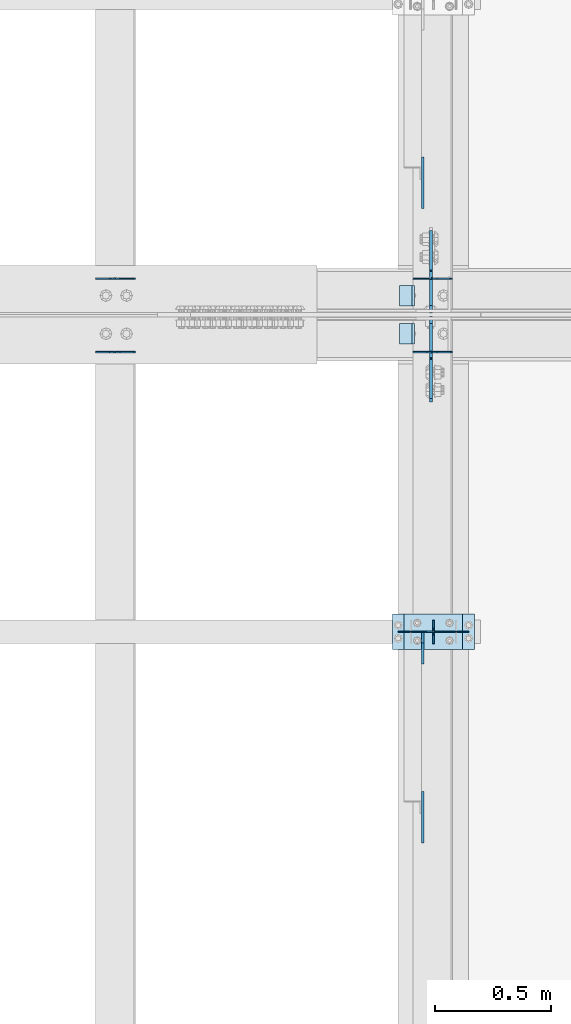
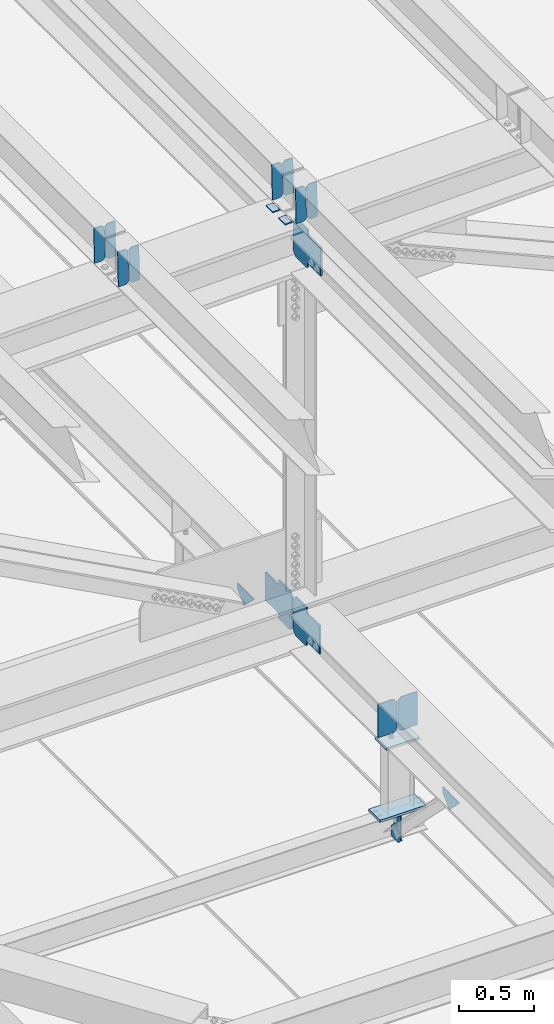
# One storey, part 3284 of 3843: 22 plates, 10 elements without a shape of their own.
"""IFC2X3 building model written with IfcOpenShell, lengths in millimetres."""

from ifc_helpers import new_model, si_unit, frame, origin_with_axes, place, context, subcontext, project, spatial, faceted_brep, material, type_object, element, aggregate, save


model = new_model("IFC2X3")

# Units and contexts
model_context = context("Model", 3, precision=1e-05, world=origin_with_axes())
body_context = subcontext(model_context, "Body", "Model", "MODEL_VIEW")
ifc_project = project(units=[si_unit("LENGTHUNIT", "METRE", prefix="MILLI"), si_unit("AREAUNIT", "SQUARE_METRE"), si_unit("VOLUMEUNIT", "CUBIC_METRE"), si_unit("MASSUNIT", "GRAM", prefix="KILO"), si_unit("TIMEUNIT", "SECOND"), si_unit("PLANEANGLEUNIT", "RADIAN"), si_unit("SOLIDANGLEUNIT", "STERADIAN"), si_unit("THERMODYNAMICTEMPERATUREUNIT", "DEGREE_CELSIUS"), si_unit("LUMINOUSINTENSITYUNIT", "LUMEN")], contexts=[model_context])

# Site, building, storey
site_placement = place(None, origin_with_axes())
site = spatial("IfcSite", under=ifc_project, at=site_placement, CompositionType="ELEMENT")
building_placement = place(site_placement, origin_with_axes())
building = spatial("IfcBuilding", under=site, at=building_placement, Name="Undefined", CompositionType="ELEMENT")
storey_placement = place(building_placement, origin_with_axes())
storey = spatial("IfcBuildingStorey", under=building, at=storey_placement, Name="Undefined", CompositionType="ELEMENT", Elevation=0.0)

# Assembly, plates
assembly_1_placement = place(storey_placement, origin_with_axes())
assembly_1 = element("IfcElementAssembly", 1, at=assembly_1_placement, inside=storey, Name="BEAM", AssemblyPlace="NOTDEFINED", PredefinedType="RIGID_FRAME")
ifc_material = material(Name="STEEL/A572-50")
plate_type_1 = type_object("IfcPlateType", PredefinedType="NOTDEFINED")
plate_1_placement = place(assembly_1_placement, frame((42144.6964817676, 59070.8529243863, 45578.562311739), z_axis=(-0.0211520980636923, 7.39979999707428e-05, 0.999776266607585), x_axis=(-0.999776269345987, -1.58399999781977e-06, -0.021152098007311)))
plate_1 = element("IfcPlate", 2, at=plate_1_placement, type_object=plate_type_1, material=ifc_material, Name="PLATE", context=body_context, shape_type="Brep", body=[
    faceted_brep([(0.0, -3.17499999999927, 0.0), (6.83940015733242e-10, -3.17499999996653, 288.924999998613), (6.54836185276508e-10, 3.17500000001746, 288.924999998591), (0.0, 3.17499999999927, 0.0), (60.3250007643655, -3.17500000017753, 288.924999998606), (60.3250007643219, 3.17499999979918, 288.924999998584), (79.3750000013097, -3.17500000025029, 269.875000761494), (79.375000001266, 3.17499999972642, 269.875000761487), (79.375000000713, -3.17500000026484, 19.0499992370605), (79.3750000006985, 3.17499999971187, 19.0499992370533), (60.325000763667, -3.17500000020664, -1.45519152283669e-11), (60.3250007636234, 3.17499999977736, -3.63797880709171e-11)], [[[0, 1, 2, 3]], [[1, 4, 5, 2]], [[4, 6, 7, 5]], [[6, 8, 9, 7]], [[8, 10, 11, 9]], [[10, 0, 3, 11]], [[5, 7, 9, 11, 3, 2]], [[10, 8, 6, 4, 1, 0]]]),
])
plate_2_placement = place(assembly_1_placement, frame((42058.990661078, 59070.8527920629, 45576.7490481436), z_axis=(-0.0211520980636923, 7.39979999707428e-05, 0.999776266607585), x_axis=(-0.999776269345987, -1.58399999781977e-06, -0.021152098007311)))
plate_2 = element("IfcPlate", 3, at=plate_2_placement, type_object=plate_type_1, material=ifc_material, Name="PLATE", context=body_context, shape_type="Brep", body=[
    faceted_brep([(4.36557456851006e-11, -3.17499999998836, 19.0499992370969), (6.11180439591408e-10, -3.17499999996653, 269.875000761516), (5.96628524363041e-10, 3.17500000001746, 269.875000761502), (1.45519152283669e-11, 3.17499999998836, 19.0499992370824), (19.0499992376572, -3.17500000003201, 288.924999998606), (19.0499992376281, 3.1749999999447, 288.924999998584), (79.3750000013242, -3.17500000025029, 288.924999998591), (79.3750000013097, 3.1749999997337, 288.92499999857), (79.3750000006548, -3.17500000026484, -2.18278728425503e-11), (79.3750000006403, 3.17499999969732, -2.91038304567337e-11), (19.0499992370023, -3.17500000005384, 0.0), (19.0499992369587, 3.17499999992287, -1.45519152283669e-11)], [[[0, 1, 2, 3]], [[1, 4, 5, 2]], [[4, 6, 7, 5]], [[6, 8, 9, 7]], [[8, 10, 11, 9]], [[10, 0, 3, 11]], [[5, 7, 9, 11, 3, 2]], [[10, 8, 6, 4, 1, 0]]]),
])

assembly_2_placement = place(storey_placement, origin_with_axes())
assembly_2 = element("IfcElementAssembly", 4, at=assembly_2_placement, inside=storey, Name="BEAM", AssemblyPlace="NOTDEFINED", PredefinedType="RIGID_FRAME")
plate_3_placement = place(assembly_2_placement, frame((42144.696478349, 58753.3983628377, 45578.5611420288), z_axis=(-0.0211520980722271, -7.83190000220203e-05, 0.999776266278249), x_axis=(-0.999776269345987, 1.58400000145775e-06, -0.021152098007311)))
plate_3 = element("IfcPlate", 5, at=plate_3_placement, type_object=plate_type_1, material=ifc_material, Name="PLATE", context=body_context, shape_type="Brep", body=[
    faceted_brep([(0.0, -3.17499999999927, 0.0), (6.83940015733242e-10, -3.17499999996653, 288.924999998613), (6.54836185276508e-10, 3.17500000001746, 288.924999998591), (0.0, 3.17499999999927, 0.0), (60.3250007643655, -3.17500000017753, 288.924999998606), (60.3250007643219, 3.17499999979918, 288.924999998584), (79.3750000013097, -3.17500000025029, 269.875000761494), (79.375000001266, 3.17499999972642, 269.875000761487), (79.375000000713, -3.17500000026484, 19.0499992370605), (79.3750000006985, 3.17499999971187, 19.0499992370533), (60.325000763667, -3.17500000020664, -1.45519152283669e-11), (60.3250007636234, 3.17499999977736, -3.63797880709171e-11)], [[[0, 1, 2, 3]], [[1, 4, 5, 2]], [[4, 6, 7, 5]], [[6, 8, 9, 7]], [[8, 10, 11, 9]], [[10, 0, 3, 11]], [[5, 7, 9, 11, 3, 2]], [[10, 8, 6, 4, 1, 0]]]),
])
plate_4_placement = place(assembly_2_placement, frame((42058.9906576593, 58753.3985048813, 45576.7478784327), z_axis=(-0.0211520980722271, -7.83190000220203e-05, 0.999776266278249), x_axis=(-0.999776269345987, 1.58400000145775e-06, -0.021152098007311)))
plate_4 = element("IfcPlate", 6, at=plate_4_placement, type_object=plate_type_1, material=ifc_material, Name="PLATE", context=body_context, shape_type="Brep", body=[
    faceted_brep([(4.36557456851006e-11, -3.17499999998836, 19.0499992370969), (6.11180439591408e-10, -3.17499999996653, 269.875000761516), (5.96628524363041e-10, 3.17500000001746, 269.875000761502), (1.45519152283669e-11, 3.17499999998836, 19.0499992370824), (19.0499992376572, -3.17500000003201, 288.924999998606), (19.0499992376281, 3.1749999999447, 288.924999998584), (79.3750000013242, -3.17500000025029, 288.924999998591), (79.3750000013097, 3.1749999997337, 288.92499999857), (79.3750000006548, -3.17500000026484, -2.18278728425503e-11), (79.3750000006403, 3.17499999969732, -2.91038304567337e-11), (19.0499992370023, -3.17500000005384, 0.0), (19.0499992369587, 3.17499999992287, -1.45519152283669e-11)], [[[0, 1, 2, 3]], [[1, 4, 5, 2]], [[4, 6, 7, 5]], [[6, 8, 9, 7]], [[8, 10, 11, 9]], [[10, 0, 3, 11]], [[5, 7, 9, 11, 3, 2]], [[10, 8, 6, 4, 1, 0]]]),
])

assembly_3_placement = place(storey_placement, origin_with_axes())
assembly_3 = element("IfcElementAssembly", 7, at=assembly_3_placement, inside=storey, Name="BEAM", AssemblyPlace="NOTDEFINED", PredefinedType="RIGID_FRAME")
plate_5_placement = place(assembly_3_placement, frame((40773.0964741001, 59070.8557457717, 45542.3034593218), z_axis=(-0.0211520980514033, 6.45460000159801e-05, 0.99977626726275), x_axis=(-0.999776269345987, -1.58399999781977e-06, -0.021152098007311)))
plate_5 = element("IfcPlate", 8, at=plate_5_placement, type_object=plate_type_1, material=ifc_material, Name="PLATE", context=body_context, shape_type="Brep", body=[
    faceted_brep([(0.0, -3.17499999999927, 0.0), (6.83940015733242e-10, -3.17499999996653, 288.924999998613), (6.54836185276508e-10, 3.17500000001746, 288.924999998591), (0.0, 3.17499999999927, 0.0), (60.3250007643655, -3.17500000017753, 288.924999998606), (60.3250007643219, 3.17499999979918, 288.924999998584), (79.3750000013097, -3.17500000025029, 269.875000761494), (79.375000001266, 3.17499999972642, 269.875000761487), (79.375000000713, -3.17500000026484, 19.0499992370605), (79.3750000006985, 3.17499999971187, 19.0499992370533), (60.325000763667, -3.17500000020664, -1.45519152283669e-11), (60.3250007636234, 3.17499999977736, -3.63797880709171e-11)], [[[0, 1, 2, 3]], [[1, 4, 5, 2]], [[4, 6, 7, 5]], [[6, 8, 9, 7]], [[8, 10, 11, 9]], [[10, 0, 3, 11]], [[5, 7, 9, 11, 3, 2]], [[10, 8, 6, 4, 1, 0]]]),
])
plate_6_placement = place(assembly_3_placement, frame((40687.3906534104, 59070.8556287915, 45540.4901957237), z_axis=(-0.0211520980514033, 6.45460000159801e-05, 0.99977626726275), x_axis=(-0.999776269345987, -1.58399999781977e-06, -0.021152098007311)))
plate_6 = element("IfcPlate", 9, at=plate_6_placement, type_object=plate_type_1, material=ifc_material, Name="PLATE", context=body_context, shape_type="Brep", body=[
    faceted_brep([(4.36557456851006e-11, -3.17499999998836, 19.0499992370969), (6.11180439591408e-10, -3.17499999996653, 269.875000761516), (5.96628524363041e-10, 3.17500000001746, 269.875000761502), (1.45519152283669e-11, 3.17499999998836, 19.0499992370824), (19.0499992376572, -3.17500000003201, 288.924999998606), (19.0499992376281, 3.1749999999447, 288.924999998584), (79.3750000013242, -3.17500000025029, 288.924999998591), (79.3750000013097, 3.1749999997337, 288.92499999857), (79.3750000006548, -3.17500000026484, -2.18278728425503e-11), (79.3750000006403, 3.17499999969732, -2.91038304567337e-11), (19.0499992370023, -3.17500000005384, 0.0), (19.0499992369587, 3.17499999992287, -1.45519152283669e-11)], [[[0, 1, 2, 3]], [[1, 4, 5, 2]], [[4, 6, 7, 5]], [[6, 8, 9, 7]], [[8, 10, 11, 9]], [[10, 0, 3, 11]], [[5, 7, 9, 11, 3, 2]], [[10, 8, 6, 4, 1, 0]]]),
])
aggregate(assembly_3, [plate_5, plate_6])

assembly_4_placement = place(storey_placement, origin_with_axes())
assembly_4 = element("IfcElementAssembly", 10, at=assembly_4_placement, inside=storey, Name="BEAM", AssemblyPlace="NOTDEFINED", PredefinedType="RIGID_FRAME")
plate_7_placement = place(assembly_4_placement, frame((40773.0964699703, 58753.3940232659, 45542.3031772535), z_axis=(-0.0211520980503264, -6.37720000231637e-05, 0.999776267312443), x_axis=(-0.999776269345987, 1.58400000145775e-06, -0.021152098007311)))
plate_7 = element("IfcPlate", 11, at=plate_7_placement, type_object=plate_type_1, material=ifc_material, Name="PLATE", context=body_context, shape_type="Brep", body=[
    faceted_brep([(0.0, -3.17499999999927, 0.0), (6.83940015733242e-10, -3.17499999996653, 288.924999998613), (6.54836185276508e-10, 3.17500000001746, 288.924999998591), (0.0, 3.17499999999927, 0.0), (60.3250007643655, -3.17500000017753, 288.924999998606), (60.3250007643219, 3.17499999979918, 288.924999998584), (79.3750000013097, -3.17500000025029, 269.875000761494), (79.375000001266, 3.17499999972642, 269.875000761487), (79.375000000713, -3.17500000026484, 19.0499992370605), (79.3750000006985, 3.17499999971187, 19.0499992370533), (60.325000763667, -3.17500000020664, -1.45519152283669e-11), (60.3250007636234, 3.17499999977736, -3.63797880709171e-11)], [[[0, 1, 2, 3]], [[1, 4, 5, 2]], [[4, 6, 7, 5]], [[6, 8, 9, 7]], [[8, 10, 11, 9]], [[10, 0, 3, 11]], [[5, 7, 9, 11, 3, 2]], [[10, 8, 6, 4, 1, 0]]]),
])
plate_8_placement = place(assembly_4_placement, frame((40687.3906492809, 58753.3941389279, 45540.4899136555), z_axis=(-0.0211520980503264, -6.37720000231637e-05, 0.999776267312443), x_axis=(-0.999776269345987, 1.58400000145775e-06, -0.021152098007311)))
plate_8 = element("IfcPlate", 12, at=plate_8_placement, type_object=plate_type_1, material=ifc_material, Name="PLATE", context=body_context, shape_type="Brep", body=[
    faceted_brep([(4.36557456851006e-11, -3.17499999998836, 19.0499992370969), (6.11180439591408e-10, -3.17499999996653, 269.875000761516), (5.96628524363041e-10, 3.17500000001746, 269.875000761502), (1.45519152283669e-11, 3.17499999998836, 19.0499992370824), (19.0499992376572, -3.17500000003201, 288.924999998606), (19.0499992376281, 3.1749999999447, 288.924999998584), (79.3750000013242, -3.17500000025029, 288.924999998591), (79.3750000013097, 3.1749999997337, 288.92499999857), (79.3750000006548, -3.17500000026484, -2.18278728425503e-11), (79.3750000006403, 3.17499999969732, -2.91038304567337e-11), (19.0499992370023, -3.17500000005384, 0.0), (19.0499992369587, 3.17499999992287, -1.45519152283669e-11)], [[[0, 1, 2, 3]], [[1, 4, 5, 2]], [[4, 6, 7, 5]], [[6, 8, 9, 7]], [[8, 10, 11, 9]], [[10, 0, 3, 11]], [[5, 7, 9, 11, 3, 2]], [[10, 8, 6, 4, 1, 0]]]),
])
aggregate(assembly_4, [plate_7, plate_8])

assembly_5_placement = place(storey_placement, origin_with_axes())
assembly_5 = element("IfcElementAssembly", 13, at=assembly_5_placement, inside=storey, Name="BEAM", AssemblyPlace="NOTDEFINED", PredefinedType="RIGID_FRAME")
plate_type_2 = type_object("IfcPlateType", PredefinedType="NOTDEFINED")
plate_9_placement = place(assembly_5_placement, frame((42062.4, 57492.9, 41495.6625), z_axis=(0.0, 0.0, -1.0), x_axis=(0.0, 1.0, 0.0)))
plate_9 = element("IfcPlate", 14, at=plate_9_placement, type_object=plate_type_2, material=ifc_material, Name="PLATE", context=body_context, shape_type="Brep", body=[
    faceted_brep([(0.0, -3.17499999999927, 0.0), (0.0, -3.17500000000291, 187.324999999997), (0.0, 3.17500000000291, 187.324999999997), (0.0, 3.17499999999927, 0.0), (34.9250001907349, -3.17500000000291, 187.324999999997), (34.9250001907349, 3.17500000000291, 187.324999999997), (47.625, -3.17500000000291, 174.625000190732), (47.625, 3.17500000000291, 174.625000190732), (47.625, -3.17499999999927, 12.6999998092651), (47.625, 3.17499999999927, 12.6999998092651), (34.9250001907349, -3.17499999999927, 0.0), (34.9250001907349, 3.17499999999927, 0.0)], [[[0, 1, 2, 3]], [[1, 4, 5, 2]], [[4, 6, 7, 5]], [[6, 8, 9, 7]], [[8, 10, 11, 9]], [[10, 0, 3, 11]], [[5, 7, 9, 11, 3, 2]], [[10, 8, 6, 4, 1, 0]]]),
])
plate_10_placement = place(assembly_5_placement, frame((42062.4, 57594.5, 41495.6625), z_axis=(0.0, 0.0, -1.0), x_axis=(0.0, -1.0, 0.0)))
plate_10 = element("IfcPlate", 15, at=plate_10_placement, type_object=plate_type_2, material=ifc_material, Name="PLATE", context=body_context, shape_type="Brep", body=[
    faceted_brep([(0.0, -3.17499999999927, 0.0), (0.0, -3.17500000000291, 187.324999999997), (0.0, 3.17500000000291, 187.324999999997), (0.0, 3.17499999999927, 0.0), (34.9250001907349, -3.17500000000291, 187.324999999997), (34.9250001907349, 3.17500000000291, 187.324999999997), (47.625, -3.17500000000291, 174.625000190732), (47.625, 3.17500000000291, 174.625000190732), (47.625, -3.17499999999927, 12.6999998092651), (47.625, 3.17499999999927, 12.6999998092651), (34.9250001907349, -3.17499999999927, 0.0), (34.9250001907349, 3.17499999999927, 0.0)], [[[0, 1, 2, 3]], [[1, 4, 5, 2]], [[4, 6, 7, 5]], [[6, 8, 9, 7]], [[8, 10, 11, 9]], [[10, 0, 3, 11]], [[5, 7, 9, 11, 3, 2]], [[10, 8, 6, 4, 1, 0]]]),
])

# Plate
plate_type_3 = type_object("IfcPlateType", PredefinedType="NOTDEFINED")
plate_11_placement = place(assembly_1_placement, frame((41979.7677320934, 59042.3, 45568.7330346883), z_axis=(0.0, -1.0, 0.0), x_axis=(-0.999776270257024, 0.0, -0.0211520550054595)))
plate_11 = element("IfcPlate", 16, at=plate_11_placement, type_object=plate_type_3, material=ifc_material, Name="PLATE", context=body_context, shape_type="Brep", body=[
    faceted_brep([(9.52499999982683, -4.7625000001135, 88.8999999999942), (0.0, 4.76249999999709, 88.9000015258789), (0.0, 4.76249999999709, 0.0), (9.52499999981956, -4.76249999999709, 0.0), (63.4999984608512, -4.76249999988795, 88.8999999999796), (63.4999984608367, -4.76249999988795, -1.45519152283669e-11), (63.4999984608221, 4.76250000013533, -1.45519152283669e-11), (63.4999984608367, 4.76250000013533, 88.8999999999796)], [[[0, 1, 2, 3]], [[4, 5, 6, 7]], [[5, 4, 0, 3]], [[6, 5, 3, 2]], [[7, 6, 2, 1]], [[4, 7, 1, 0]]]),
])

aggregate(assembly_1, [plate_1, plate_2, plate_11])

plate_12_placement = place(assembly_2_placement, frame((41979.7677320934, 58877.2000015258, 45568.7330346883), z_axis=(0.0, -1.0, 0.0), x_axis=(-0.999776270257024, 0.0, -0.0211520550054595)))
plate_12 = element("IfcPlate", 17, at=plate_12_placement, type_object=plate_type_3, material=ifc_material, Name="PLATE", context=body_context, shape_type="Brep", body=[
    faceted_brep([(9.52499999982683, -4.7625000001135, 88.8999999999942), (0.0, 4.76249999999709, 88.9000015258789), (0.0, 4.76249999999709, 0.0), (9.52499999981956, -4.76249999999709, 0.0), (63.4999984608512, -4.76249999988795, 88.8999999999796), (63.4999984608367, -4.76249999988795, -1.45519152283669e-11), (63.4999984608221, 4.76250000013533, -1.45519152283669e-11), (63.4999984608367, 4.76250000013533, 88.8999999999796)], [[[0, 1, 2, 3]], [[4, 5, 6, 7]], [[5, 4, 0, 3]], [[6, 5, 3, 2]], [[7, 6, 2, 1]], [[4, 7, 1, 0]]]),
])

aggregate(assembly_2, [plate_3, plate_4, plate_12])

# Assembly, plates
assembly_6_placement = place(storey_placement, origin_with_axes())
assembly_6 = element("IfcElementAssembly", 18, at=assembly_6_placement, inside=storey, Name="BEAM", AssemblyPlace="NOTDEFINED", PredefinedType="RIGID_FRAME")
plate_type_4 = type_object("IfcPlateType", PredefinedType="NOTDEFINED")
plate_13_placement = place(assembly_6_placement, frame((42051.287570703, 58908.156250009, 42150.7638889126), z_axis=(0.0, -0.707106781186682, 0.707106781186413), x_axis=(0.0, -0.707106781186548, -0.707106781186548)))
plate_13 = element("IfcPlate", 19, at=plate_13_placement, type_object=plate_type_4, material=ifc_material, Name="PLATE", context=body_context, shape_type="Brep", body=[
    faceted_brep([(0.0, -6.3499999046162, 0.0), (-179.561608404474, -6.34999999999854, 179.561608405225), (-179.561608404474, 6.34999999999854, 179.561608405225), (7.27595761418343e-12, 6.3499999046162, 0.0), (-179.561608404387, -6.34999999999854, 224.462889010594), (-179.561608404387, 6.34999999999854, 224.462889010594), (-75.7273969992675, -6.34999999999854, 328.297100415262), (-75.7273969992675, 6.34999999999854, 328.297100415262), (-53.3257730556215, -6.34999999999854, 305.895476471533), (-53.3257730556215, 6.34999999999854, 305.895476471533), (-49.2055965874897, -6.34999999999854, 303.142462571044), (-49.2055965874897, 6.34999999999854, 303.142462571044), (-44.3455170694506, -6.34999999999854, 302.175732648453), (-44.3455170694506, 6.34999999999854, 302.175732648453), (-39.4854375514115, -6.34999999999854, 303.142462571026), (-39.4854375514115, 6.34999999999854, 303.142462571026), (-35.3652610832651, -6.34999999999854, 305.895476471489), (-35.3652610832651, 6.34999999999854, 305.895476471489), (81.3780686208047, -6.34999999999854, 422.638806175071), (81.3780686208047, 6.34999999999854, 422.638806175071), (243.022678799782, -6.34999999999854, 260.994195995432), (243.022678799782, 6.34999999999854, 260.994195995432), (126.279349095697, -6.34999999999854, 144.250866291846), (126.279349095697, 6.34999999999854, 144.250866291846), (123.526335195202, -6.34999999999854, 140.130689823704), (123.526335195202, 6.34999999999854, 140.130689823704), (122.559605272618, -6.34999999999854, 135.270610305675), (122.559605272618, 6.34999999999854, 135.270610305675), (123.526335195187, -6.34999999999854, 130.410530787633), (123.526335195187, 6.34999999999854, 130.410530787633), (126.279349095639, -6.34999999999854, 126.29035431949), (126.279349095639, 6.34999999999854, 126.29035431949), (148.735492004496, -6.35000000000582, 103.834211399357), (148.735492004496, 6.35000000000582, 103.834211399357), (44.9012806051323, -6.35000000000582, -1.45519152283669e-11), (44.9012806051323, 6.35000000000582, -1.45519152283669e-11)], [[[0, 1, 2, 3]], [[1, 4, 5, 2]], [[4, 6, 7, 5]], [[6, 8, 9, 7]], [[8, 10, 11, 9]], [[10, 12, 13, 11]], [[12, 14, 15, 13]], [[14, 16, 17, 15]], [[16, 18, 19, 17]], [[18, 20, 21, 19]], [[20, 22, 23, 21]], [[22, 24, 25, 23]], [[24, 26, 27, 25]], [[26, 28, 29, 27]], [[28, 30, 31, 29]], [[30, 32, 33, 31]], [[32, 34, 35, 33]], [[34, 0, 3, 35]], [[5, 7, 9, 11, 13, 15, 17, 19, 21, 23, 25, 27, 29, 31, 33, 35, 3, 2]], [[34, 32, 30, 28, 26, 24, 22, 20, 18, 16, 14, 12, 10, 8, 6, 4, 1, 0]]]),
])
plate_14_placement = place(assembly_6_placement, frame((42051.2875000616, 58922.44375, 42150.7638885381), z_axis=(0.0, 0.707106781186548, 0.707106781186548), x_axis=(5.70000238222118e-08, 0.707106781186546, -0.707106781186546)))
plate_14 = element("IfcPlate", 20, at=plate_14_placement, type_object=plate_type_4, material=ifc_material, Name="PLATE", context=body_context, shape_type="Brep", body=[
    faceted_brep([(0.0, -6.3499999046162, 0.0), (-179.561608404474, -6.34999999999854, 179.561608405225), (-179.561608404474, 6.34999999999854, 179.561608405225), (7.27595761418343e-12, 6.3499999046162, 0.0), (-179.561608404387, -6.34999999999854, 224.462889010594), (-179.561608404387, 6.34999999999854, 224.462889010594), (-75.7273969992675, -6.34999999999854, 328.297100415262), (-75.7273969992675, 6.34999999999854, 328.297100415262), (-53.3257730556215, -6.34999999999854, 305.895476471533), (-53.3257730556215, 6.34999999999854, 305.895476471533), (-49.2055965874897, -6.34999999999854, 303.142462571044), (-49.2055965874897, 6.34999999999854, 303.142462571044), (-44.3455170694506, -6.34999999999854, 302.175732648453), (-44.3455170694506, 6.34999999999854, 302.175732648453), (-39.4854375514115, -6.34999999999854, 303.142462571026), (-39.4854375514115, 6.34999999999854, 303.142462571026), (-35.3652610832651, -6.34999999999854, 305.895476471489), (-35.3652610832651, 6.34999999999854, 305.895476471489), (81.3780686208047, -6.34999999999854, 422.638806175071), (81.3780686208047, 6.34999999999854, 422.638806175071), (243.022678799782, -6.34999999999854, 260.994195995432), (243.022678799782, 6.34999999999854, 260.994195995432), (126.279349095697, -6.34999999999854, 144.250866291846), (126.279349095697, 6.34999999999854, 144.250866291846), (123.526335195202, -6.34999999999854, 140.130689823704), (123.526335195202, 6.34999999999854, 140.130689823704), (122.559605272618, -6.34999999999854, 135.270610305675), (122.559605272618, 6.34999999999854, 135.270610305675), (123.526335195187, -6.34999999999854, 130.410530787633), (123.526335195187, 6.34999999999854, 130.410530787633), (126.279349095639, -6.34999999999854, 126.29035431949), (126.279349095639, 6.34999999999854, 126.29035431949), (148.735492004496, -6.35000000000582, 103.834211399357), (148.735492004496, 6.35000000000582, 103.834211399357), (44.9012806051323, -6.35000000000582, -1.45519152283669e-11), (44.9012806051323, 6.35000000000582, -1.45519152283669e-11)], [[[0, 1, 2, 3]], [[1, 4, 5, 2]], [[4, 6, 7, 5]], [[6, 8, 9, 7]], [[8, 10, 11, 9]], [[10, 12, 13, 11]], [[12, 14, 15, 13]], [[14, 16, 17, 15]], [[16, 18, 19, 17]], [[18, 20, 21, 19]], [[20, 22, 23, 21]], [[22, 24, 25, 23]], [[24, 26, 27, 25]], [[26, 28, 29, 27]], [[28, 30, 31, 29]], [[30, 32, 33, 31]], [[32, 34, 35, 33]], [[34, 0, 3, 35]], [[5, 7, 9, 11, 13, 15, 17, 19, 21, 23, 25, 27, 29, 31, 33, 35, 3, 2]], [[34, 32, 30, 28, 26, 24, 22, 20, 18, 16, 14, 12, 10, 8, 6, 4, 1, 0]]]),
])
aggregate(assembly_6, [plate_13, plate_14])

# Assembly, plate
assembly_7_placement = place(storey_placement, origin_with_axes())
assembly_7 = element("IfcElementAssembly", 21, at=assembly_7_placement, inside=storey, Name="BEAM", AssemblyPlace="NOTDEFINED", PredefinedType="RIGID_FRAME")
plate_15_placement = place(assembly_7_placement, frame((42051.2875705441, 58904.1875000337, 45241.617651924), z_axis=(0.0, -0.707106781186682, 0.707106781186413), x_axis=(0.0, -0.707106781186548, -0.707106781186548)))
plate_15 = element("IfcPlate", 22, at=plate_15_placement, type_object=plate_type_4, material=ifc_material, Name="PLATE", context=body_context, shape_type="Brep", body=[
    faceted_brep([(0.0, -6.3499999046162, 0.0), (-179.447476957706, -6.34999999999854, 179.44747695771), (-179.447476957706, 6.34999999999854, 179.44747695771), (7.27595761418343e-12, 6.3499999046162, 0.0), (-179.447476957706, -6.34999999999854, 224.348757562839), (-179.447476957706, 6.34999999999854, 224.348757562839), (-68.3168074600108, -6.34999999999854, 335.479427060527), (-68.3168074600108, 6.34999999999854, 335.479427060527), (-46.1378915319801, -6.34999999999854, 313.300511132507), (-46.1378915319801, 6.34999999999854, 313.300511132507), (-42.0177150638483, -6.34999999999854, 310.547497232033), (-42.0177150638483, 6.34999999999854, 310.547497232033), (-37.1576355458092, -6.34999999999854, 309.580767309446), (-37.1576355458092, 6.34999999999854, 309.580767309446), (-32.29755602777, -6.34999999999854, 310.547497232033), (-32.29755602777, 6.34999999999854, 310.547497232033), (-28.1773795596382, -6.34999999999854, 313.300511132504), (-28.1773795596382, 6.34999999999854, 313.300511132504), (88.5659501485497, -6.34999999999854, 430.043840840692), (88.5659501485497, 6.34999999999854, 430.043840840692), (250.210560327017, -6.34999999999854, 268.39923066222), (250.210560327017, 6.34999999999854, 268.39923066222), (133.467230618844, -6.34999999999854, 151.655900954032), (133.467230618844, 6.34999999999854, 151.655900954032), (130.714216718363, -6.34999999999854, 147.53572448589), (130.714216718363, 6.34999999999854, 147.53572448589), (129.747486795779, -6.34999999999854, 142.675644967854), (129.747486795779, 6.34999999999854, 142.675644967854), (130.714216718363, -6.34999999999854, 137.815565449819), (130.714216718363, 6.34999999999854, 137.815565449819), (133.467230618844, -6.34999999999854, 133.695388981676), (133.467230618844, 6.34999999999854, 133.695388981676), (156.031950102829, -6.35000000000582, 111.130669497703), (156.031950102829, 6.35000000000582, 111.130669497703), (44.9012806051323, -6.35000000000582, -1.45519152283669e-11), (44.9012806051323, 6.35000000000582, -1.45519152283669e-11)], [[[0, 1, 2, 3]], [[1, 4, 5, 2]], [[4, 6, 7, 5]], [[6, 8, 9, 7]], [[8, 10, 11, 9]], [[10, 12, 13, 11]], [[12, 14, 15, 13]], [[14, 16, 17, 15]], [[16, 18, 19, 17]], [[18, 20, 21, 19]], [[20, 22, 23, 21]], [[22, 24, 25, 23]], [[24, 26, 27, 25]], [[26, 28, 29, 27]], [[28, 30, 31, 29]], [[30, 32, 33, 31]], [[32, 34, 35, 33]], [[34, 0, 3, 35]], [[5, 7, 9, 11, 13, 15, 17, 19, 21, 23, 25, 27, 29, 31, 33, 35, 3, 2]], [[34, 32, 30, 28, 26, 24, 22, 20, 18, 16, 14, 12, 10, 8, 6, 4, 1, 0]]]),
])
aggregate(assembly_7, [plate_15])

# Assembly, plates
assembly_8_placement = place(storey_placement, origin_with_axes())
assembly_8 = element("IfcElementAssembly", 23, at=assembly_8_placement, inside=storey, Name="POST", AssemblyPlace="NOTDEFINED", PredefinedType="RIGID_FRAME")
plate_type_5 = type_object("IfcPlateType", PredefinedType="NOTDEFINED")
plate_16_placement = place(assembly_8_placement, frame((41935.3999968995, 57619.9007403097, 42083.0375000289), z_axis=(0.0, -0.999999996977702, -7.77469999939545e-05), x_axis=(1.0, 0.0, 0.0)))
plate_16 = element("IfcPlate", 24, at=plate_16_placement, type_object=plate_type_5, material=ifc_material, Name="PLATE", context=body_context, shape_type="Brep", body=[
    faceted_brep([(0.0, -9.52500000000146, 0.0), (0.0, -9.5249999999287, 152.40000000162), (0.0, 9.52500000002328, 152.40000000162), (0.0, 9.52500000000146, 0.0), (254.0, -9.5249999999287, 152.40000000162), (254.0, 9.52500000002328, 152.40000000162), (253.999999999998, -9.52500000000146, 0.0), (253.999999999998, 9.52500000000146, 0.0)], [[[0, 1, 2, 3]], [[1, 4, 5, 2]], [[4, 6, 7, 5]], [[6, 0, 3, 7]], [[5, 7, 3, 2]], [[6, 4, 1, 0]]]),
])
plate_17_placement = place(assembly_8_placement, frame((42240.2, 57467.5, 41513.125), z_axis=(-1.0, 0.0, 0.0), x_axis=(0.0, 1.0, 0.0)))
plate_17 = element("IfcPlate", 25, at=plate_17_placement, type_object=plate_type_5, material=ifc_material, Name="PLATE", context=body_context, shape_type="Brep", body=[
    faceted_brep([(0.0, -9.52500000000146, 0.0), (0.0, -9.52500000000146, 355.599999999999), (0.0, 9.52500000000146, 355.599999999999), (0.0, 9.52500000000146, 0.0), (152.399999999994, -9.52500000000146, 355.599999999999), (152.399999999994, 9.52500000000146, 355.599999999999), (152.400000000001, -9.52500000000146, 0.0), (152.400000000001, 9.52500000000146, 0.0)], [[[0, 1, 2, 3]], [[1, 4, 5, 2]], [[4, 6, 7, 5]], [[6, 0, 3, 7]], [[5, 7, 3, 2]], [[6, 4, 1, 0]]]),
])
aggregate(assembly_8, [plate_16, plate_17])

# Assembly, plate
assembly_9_placement = place(storey_placement, origin_with_axes())
assembly_9 = element("IfcElementAssembly", 26, at=assembly_9_placement, inside=storey, Name="BEAM", AssemblyPlace="NOTDEFINED", PredefinedType="RIGID_FRAME")
plate_type_6 = type_object("IfcPlateType", PredefinedType="NOTDEFINED")
plate_18_placement = place(assembly_9_placement, frame((42016.3625, 56630.5715655367, 42123.6324118969), z_axis=(0.0, 0.707106781186548, 0.707106781186548), x_axis=(5.70000238222118e-08, 0.707106781186546, -0.707106781186546)))
plate_18 = element("IfcPlate", 27, at=plate_18_placement, type_object=plate_type_6, material=ifc_material, Name="PLATE", context=body_context, shape_type="Brep", body=[
    faceted_brep([(0.0, -4.76249999999709, 0.0), (157.726597423803, -4.76249999999709, 157.726601438866), (157.726597423803, 4.76249999999709, 157.726601438866), (0.0, 4.76249999999709, 0.0), (188.387110059113, -4.76249999999709, 127.066089584019), (188.387110059113, 4.76249999999709, 127.066089584019), (188.387111679331, -4.76249999999709, 1.09139364212751e-10), (188.387111679331, 4.76249999999709, 1.09139364212751e-10)], [[[0, 1, 2, 3]], [[1, 4, 5, 2]], [[4, 6, 7, 5]], [[6, 0, 3, 7]], [[5, 7, 3, 2]], [[6, 4, 1, 0]]]),
])

assembly_10_placement = place(storey_placement, origin_with_axes())
assembly_10 = element("IfcElementAssembly", 28, at=assembly_10_placement, inside=storey, Name="BEAM", AssemblyPlace="NOTDEFINED", PredefinedType="RIGID_FRAME")
plate_19_placement = place(assembly_10_placement, frame((42016.3625, 59373.6433427282, 42123.7606346845), z_axis=(0.0, 0.707106781186548, 0.707106781186548), x_axis=(5.70000238222118e-08, 0.707106781186546, -0.707106781186546)))
plate_19 = element("IfcPlate", 29, at=plate_19_placement, type_object=plate_type_6, material=ifc_material, Name="PLATE", context=body_context, shape_type="Brep", body=[
    faceted_brep([(0.0, -4.76249999999709, 0.0), (157.726597423803, -4.76249999999709, 157.726601438866), (157.726597423803, 4.76249999999709, 157.726601438866), (0.0, 4.76249999999709, 0.0), (188.387110059113, -4.76249999999709, 127.066089584019), (188.387110059113, 4.76249999999709, 127.066089584019), (188.387111679331, -4.76249999999709, 1.09139364212751e-10), (188.387111679331, 4.76249999999709, 1.09139364212751e-10)], [[[0, 1, 2, 3]], [[1, 4, 5, 2]], [[4, 6, 7, 5]], [[6, 0, 3, 7]], [[5, 7, 3, 2]], [[6, 4, 1, 0]]]),
])
aggregate(assembly_10, [plate_19])

# Plate
plate_type_7 = type_object("IfcPlateType", PredefinedType="NOTDEFINED")
plate_20_placement = place(assembly_5_placement, frame((42016.3625, 57540.5250000347, 41306.750000025), z_axis=(0.0, -1.0, 0.0), x_axis=(0.0, 0.0, 1.0)))
plate_20 = element("IfcPlate", 30, at=plate_20_placement, type_object=plate_type_7, material=ifc_material, Name="PLATE", context=body_context, shape_type="Brep", body=[
    faceted_brep([(0.0, -4.76250000000073, 12.6999998092651), (4.450703272596e-08, -4.76249999999709, 93.0710244828806), (4.450703272596e-08, 4.76249999999709, 93.0710244828806), (0.0, 4.76250000000073, 12.6999998092651), (43.3137807601452, -4.76249999999709, 136.384805065652), (43.3137807601452, 4.76249999999709, 136.384805065652), (133.209805202001, -4.76249999999709, 46.4887805392646), (133.209805202001, 4.76249999999709, 46.4887805392646), (86.7210245267561, -4.76249999999709, 0.0), (86.7210245267561, 4.76249999999709, 0.0), (12.6999998092651, -4.76250000000073, 0.0), (12.6999998092651, 4.76250000000073, 0.0)], [[[0, 1, 2, 3]], [[1, 4, 5, 2]], [[4, 6, 7, 5]], [[6, 8, 9, 7]], [[8, 10, 11, 9]], [[10, 0, 3, 11]], [[5, 7, 9, 11, 3, 2]], [[10, 8, 6, 4, 1, 0]]]),
])

aggregate(assembly_5, [plate_20, plate_9, plate_10])

plate_type_8 = type_object("IfcPlateType", PredefinedType="NOTDEFINED")
plate_21_placement = place(assembly_9_placement, frame((42214.8, 57543.6774135246, 42414.2089148851), z_axis=(0.0, 7.77469999957245e-05, -0.999999996977702), x_axis=(-1.0, 0.0, 0.0)))
plate_21 = element("IfcPlate", 31, at=plate_21_placement, type_object=plate_type_8, material=ifc_material, Name="PLATE", context=body_context, shape_type="Brep", body=[
    faceted_brep([(0.0, -3.17499999999927, 0.0), (0.0, -3.17500000007567, 273.049999997937), (0.0, 3.17499999993743, 273.049999997937), (0.0, 3.17499999999927, 0.0), (122.237500389827, -3.17500000007567, 273.049999997937), (122.237500389827, 3.17499999993743, 273.049999997937), (147.637500008357, -3.17500000006476, 247.650000379464), (147.637500008357, 3.17499999994106, 247.650000379464), (147.637500008357, -3.17500000001382, 25.3999996184648), (147.637500008357, 3.17499999999927, 25.3999996184648), (122.237500389827, -3.17500000000291, 0.0), (122.237500389827, 3.17500000000291, -7.27595761418343e-12)], [[[0, 1, 2, 3]], [[1, 4, 5, 2]], [[4, 6, 7, 5]], [[6, 8, 9, 7]], [[8, 10, 11, 9]], [[10, 0, 3, 11]], [[5, 7, 9, 11, 3, 2]], [[10, 8, 6, 4, 1, 0]]]),
])

plate_22_placement = place(assembly_9_placement, frame((41910.0, 57543.6774135246, 42414.2089148851), z_axis=(0.0, 7.77469999957245e-05, -0.999999996977702), x_axis=(1.0, 0.0, 0.0)))
plate_22 = element("IfcPlate", 32, at=plate_22_placement, type_object=plate_type_8, material=ifc_material, Name="PLATE", context=body_context, shape_type="Brep", body=[
    faceted_brep([(0.0, -3.17499999999927, 0.0), (0.0, -3.17500000007567, 273.049999997937), (0.0, 3.17499999993743, 273.049999997937), (0.0, 3.17499999999927, 0.0), (122.237500389827, -3.17500000007567, 273.049999997937), (122.237500389827, 3.17499999993743, 273.049999997937), (147.637500008357, -3.17500000006476, 247.650000379464), (147.637500008357, 3.17499999994106, 247.650000379464), (147.637500008357, -3.17500000001382, 25.3999996184648), (147.637500008357, 3.17499999999927, 25.3999996184648), (122.237500389827, -3.17500000000291, 0.0), (122.237500389827, 3.17500000000291, -7.27595761418343e-12)], [[[0, 1, 2, 3]], [[1, 4, 5, 2]], [[4, 6, 7, 5]], [[6, 8, 9, 7]], [[8, 10, 11, 9]], [[10, 0, 3, 11]], [[5, 7, 9, 11, 3, 2]], [[10, 8, 6, 4, 1, 0]]]),
])

aggregate(assembly_9, [plate_21, plate_22, plate_18])

save(model, "model.ifc")
